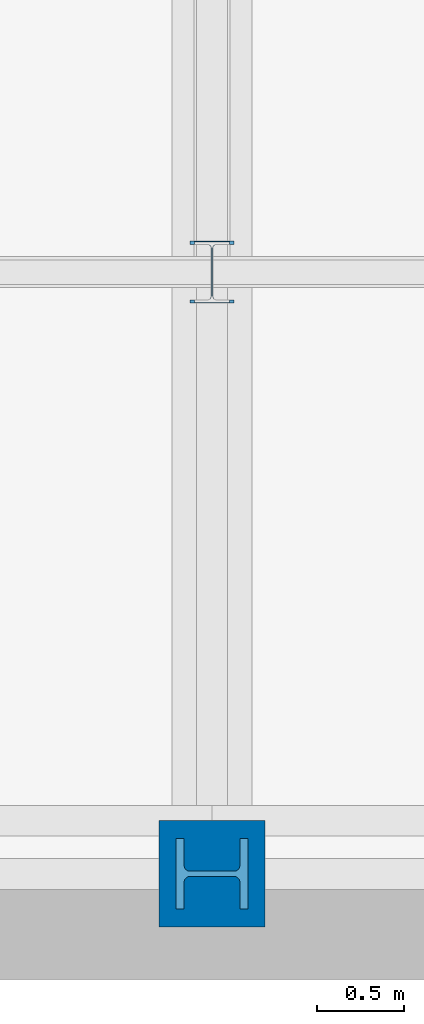
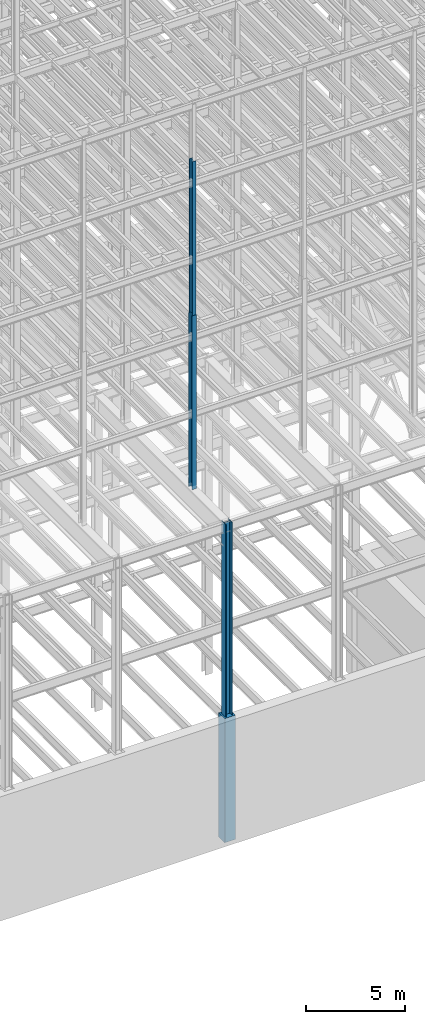
# One storey, part 20 of 150: 4 columns.
"""IFC2X3 building model written with IfcOpenShell, lengths in millimetres."""

from ifc_helpers import new_model, si_unit, frame, origin_with_axes, origin_2d_with_axis, place, context, subcontext, project, spatial, rectangle, i_section, extrude, material, type_object, element, save


model = new_model("IFC2X3")

# Units and contexts
model_context = context("Model", 3, precision=1e-05, world=origin_with_axes())
body_context = subcontext(model_context, "Body", "Model", "MODEL_VIEW")
ifc_project = project(units=[si_unit("LENGTHUNIT", "METRE", prefix="MILLI"), si_unit("AREAUNIT", "SQUARE_METRE"), si_unit("VOLUMEUNIT", "CUBIC_METRE"), si_unit("MASSUNIT", "GRAM", prefix="KILO"), si_unit("TIMEUNIT", "SECOND"), si_unit("PLANEANGLEUNIT", "RADIAN"), si_unit("SOLIDANGLEUNIT", "STERADIAN"), si_unit("THERMODYNAMICTEMPERATUREUNIT", "DEGREE_CELSIUS"), si_unit("LUMINOUSINTENSITYUNIT", "LUMEN")], contexts=[model_context])

# Site, building, storey
site_placement = place(None, origin_with_axes())
site = spatial("IfcSite", under=ifc_project, at=site_placement, CompositionType="ELEMENT")
building_placement = place(site_placement, origin_with_axes())
building = spatial("IfcBuilding", under=site, at=building_placement, Name="Undefined", CompositionType="ELEMENT")
storey_placement = place(building_placement, origin_with_axes())
storey = spatial("IfcBuildingStorey", under=building, at=storey_placement, Name="Undefined", CompositionType="ELEMENT", Elevation=0.0)

# Columns
ifc_material_1 = material(Name="STEEL/A992")
column_type_1 = type_object("IfcColumnType", Name="W14X53", PredefinedType="NOTDEFINED")
column_1_placement = place(storey_placement, frame((30988.0, 3454.39999999999, 46253.4), z_axis=(0.0, 0.0, 1.0), x_axis=(1.0, 0.0, 0.0)))
element("IfcColumn", 1, at=column_1_placement, inside=storey, type_object=column_type_1, material=ifc_material_1, Name="COLUMN", ObjectType="W14X53", context=body_context, shape_type="SweptSolid", body=[
    extrude(i_section(OverallWidth=203.2, OverallDepth=352.425, WebThickness=9.5249, FlangeThickness=16.764, FilletRadius=21.336, at=origin_2d_with_axis()), frame((0.0, 0.0, 9448.8), z_axis=(0.0, 0.0, -1.0), x_axis=(-1.0, 0.0, 0.0)), (0.0, 0.0, 1.0), 9448.8),
])
column_type_2 = type_object("IfcColumnType", Name="W14X68", PredefinedType="NOTDEFINED")
column_2_placement = place(storey_placement, frame((30988.0, 3454.39999999999, 35585.4), z_axis=(0.0, 0.0, 1.0), x_axis=(1.0, 0.0, 0.0)))
element("IfcColumn", 2, at=column_2_placement, inside=storey, type_object=column_type_2, material=ifc_material_1, Name="COLUMN", ObjectType="W14X68", context=body_context, shape_type="SweptSolid", body=[
    extrude(i_section(OverallWidth=254.0, OverallDepth=355.6, WebThickness=11.1125, FlangeThickness=18.288, FilletRadius=21.3994, at=origin_2d_with_axis()), frame((0.0, 0.0, 10668.0), z_axis=(0.0, 0.0, -1.0), x_axis=(-1.0, 0.0, 0.0)), (0.0, 0.0, 1.0), 10668.0),
])
column_type_3 = type_object("IfcColumnType", Name="W14X257", PredefinedType="NOTDEFINED")
column_3_placement = place(storey_placement, frame((30988.0, 0.0, 22707.6), z_axis=(0.0, 0.0, 1.0), x_axis=(1.0, 0.0, 0.0)))
element("IfcColumn", 3, at=column_3_placement, inside=storey, type_object=column_type_3, material=ifc_material_1, Name="COLUMN", ObjectType="W14X257", context=body_context, shape_type="SweptSolid", body=[
    extrude(i_section(OverallWidth=406.4, OverallDepth=415.925, WebThickness=30.1625, FlangeThickness=48.006, FilletRadius=32.9564, at=origin_2d_with_axis()), frame((0.0, 0.0, 12877.8), z_axis=(0.0, 0.0, -1.0), x_axis=(0.0, -1.0, 0.0)), (0.0, 0.0, 1.0), 12877.8),
])
ifc_material_2 = material(Name="CONCRETE/5000")
column_type_4 = type_object("IfcColumnType", PredefinedType="NOTDEFINED")
column_4_placement = place(storey_placement, frame((30988.0, 0.0, 16154.4), z_axis=(0.0, 0.0, 1.0), x_axis=(1.0, 0.0, 0.0)))
element("IfcColumn", 4, at=column_4_placement, inside=storey, type_object=column_type_4, material=ifc_material_2, Name="COLUMN", context=body_context, shape_type="SweptSolid", body=[
    extrude(rectangle(XDim=609.6, YDim=609.6, at=origin_2d_with_axis()), frame((0.0, 0.0, 7620.0), z_axis=(0.0, 0.0, -1.0), x_axis=(0.0, -1.0, 0.0)), (0.0, 0.0, 1.0), 7620.0),
])

save(model, "model.ifc")
